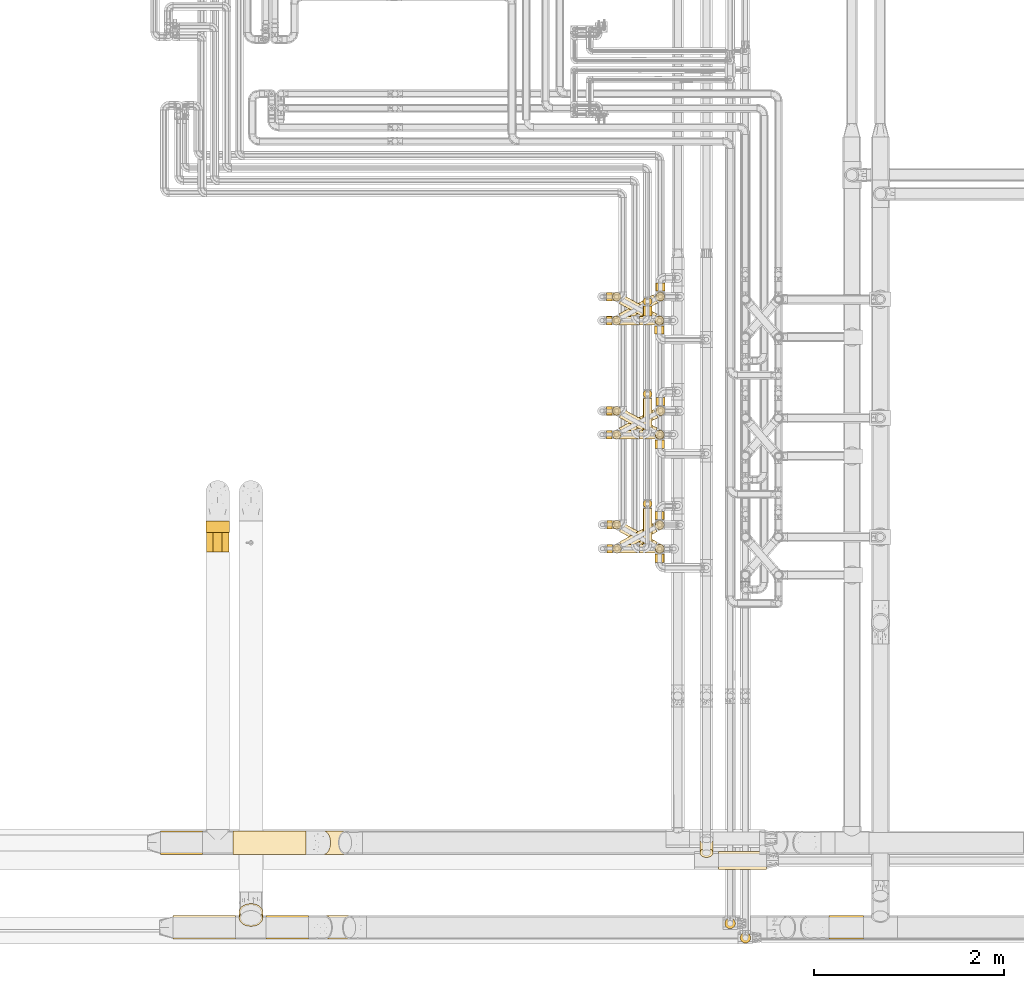
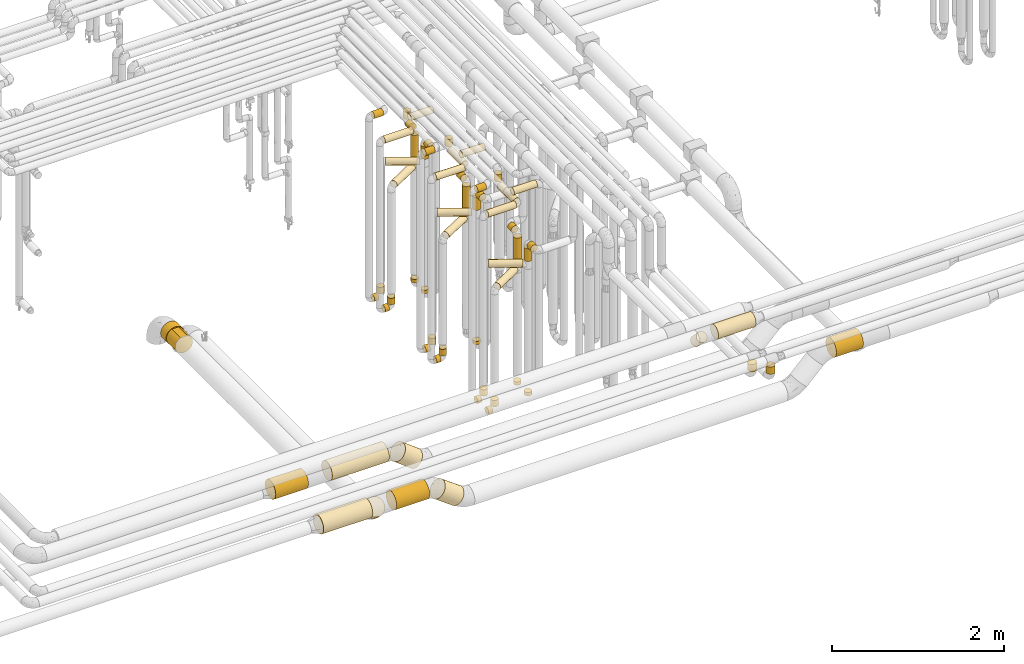
# One storey, part 11 of 827: 64 coverings.
"""IFC2X3 building model written with IfcOpenShell, lengths in millimetres."""

from ifc_helpers import new_model, entity, si_unit, converted_unit, derived_unit, direction, frame, frame_2d, origin, origin_2d_with_axis, place, context, subcontext, project, spatial, polyline, circle_curve, parameter, trimmed, segment, composite_curve, circle, outline, extrude, element, save


model = new_model("IFC2X3")

# Units and contexts
model_context = context("Model", 3, precision=0.01, world=origin(), true_north=direction((6.12303176911189e-17, 1.0)))
body_context = subcontext(model_context, "Body", "Model", "MODEL_VIEW")
ifc_project = project(units=[si_unit("LENGTHUNIT", "METRE", prefix="MILLI"), si_unit("AREAUNIT", "SQUARE_METRE"), si_unit("VOLUMEUNIT", "CUBIC_METRE"), converted_unit("PLANEANGLEUNIT", "DEGREE", entity("IfcRatioMeasure", 0.0174532925199433), si_unit("PLANEANGLEUNIT", "RADIAN"), dimensions=[0, 0, 0, 0, 0, 0, 0]), si_unit("MASSUNIT", "GRAM", prefix="KILO"), derived_unit("MASSDENSITYUNIT", [(si_unit("MASSUNIT", "GRAM", prefix="KILO"), 1), (si_unit("LENGTHUNIT", "METRE"), -3)]), derived_unit("MOMENTOFINERTIAUNIT", [(si_unit("LENGTHUNIT", "METRE"), 4)]), si_unit("TIMEUNIT", "SECOND"), si_unit("FREQUENCYUNIT", "HERTZ"), si_unit("THERMODYNAMICTEMPERATUREUNIT", "DEGREE_CELSIUS"), derived_unit("THERMALTRANSMITTANCEUNIT", [(si_unit("MASSUNIT", "GRAM", prefix="KILO"), 1), (si_unit("THERMODYNAMICTEMPERATUREUNIT", "KELVIN"), -1), (si_unit("TIMEUNIT", "SECOND"), -3)]), derived_unit("VOLUMETRICFLOWRATEUNIT", [(si_unit("LENGTHUNIT", "METRE"), 3), (si_unit("TIMEUNIT", "SECOND"), -1)]), derived_unit("MASSFLOWRATEUNIT", [(si_unit("MASSUNIT", "GRAM", prefix="KILO"), 1), (si_unit("TIMEUNIT", "SECOND"), -1)]), derived_unit("ROTATIONALFREQUENCYUNIT", [(si_unit("TIMEUNIT", "SECOND"), -1)]), si_unit("ELECTRICCURRENTUNIT", "AMPERE"), si_unit("ELECTRICVOLTAGEUNIT", "VOLT"), si_unit("POWERUNIT", "WATT"), si_unit("FORCEUNIT", "NEWTON", prefix="KILO"), si_unit("ILLUMINANCEUNIT", "LUX"), si_unit("LUMINOUSFLUXUNIT", "LUMEN"), si_unit("LUMINOUSINTENSITYUNIT", "CANDELA"), derived_unit("USERDEFINED", [(si_unit("MASSUNIT", "GRAM", prefix="KILO"), -1), (si_unit("LENGTHUNIT", "METRE"), -2), (si_unit("TIMEUNIT", "SECOND"), 3), (si_unit("LUMINOUSFLUXUNIT", "LUMEN"), 1)]), derived_unit("LINEARVELOCITYUNIT", [(si_unit("LENGTHUNIT", "METRE"), 1), (si_unit("TIMEUNIT", "SECOND"), -1)]), si_unit("PRESSUREUNIT", "PASCAL"), derived_unit("USERDEFINED", [(si_unit("LENGTHUNIT", "METRE"), -2), (si_unit("MASSUNIT", "GRAM", prefix="KILO"), 1), (si_unit("TIMEUNIT", "SECOND"), -2)]), derived_unit("LINEARFORCEUNIT", [(si_unit("MASSUNIT", "GRAM", prefix="KILO"), 1), (si_unit("LENGTHUNIT", "METRE"), 1), (si_unit("TIMEUNIT", "SECOND"), -2), (si_unit("LENGTHUNIT", "METRE"), -1)]), derived_unit("PLANARFORCEUNIT", [(si_unit("MASSUNIT", "GRAM", prefix="KILO"), 1), (si_unit("LENGTHUNIT", "METRE"), 1), (si_unit("TIMEUNIT", "SECOND"), -2), (si_unit("LENGTHUNIT", "METRE"), -2)])], contexts=[model_context])

# Site, building, storey
site_placement = place(None, origin())
site = spatial("IfcSite", under=ifc_project, at=site_placement, CompositionType="ELEMENT")
building_placement = place(site_placement, origin())
building = spatial("IfcBuilding", under=site, at=building_placement, CompositionType="ELEMENT")
storey_placement = place(building_placement, frame((0.0, 0.0, 28200.0)))
storey = spatial("IfcBuildingStorey", under=building, at=storey_placement, Name="08", CompositionType="ELEMENT", Elevation=28200.0)

# Coverings
covering_1_placement = place(storey_placement, frame((35168.03, 11508.46, 352.25)))
element("IfcCovering", 1, at=covering_1_placement, inside=storey, Name=":ADSK_", ObjectType=":ADSK_", PredefinedType="INSULATION", context=body_context, shape_type="SweptSolid", body=[
    extrude(circle(Radius=46.15, at=origin_2d_with_axis()), frame((0.0, 47.75, 47.75), z_axis=(1.0, 0.0, 0.0), x_axis=(0.0, 1.0, 0.0)), (0.0, 0.0, 1.0), 59.0000000000126),
])
covering_2_placement = place(storey_placement, frame((35227.29, 11508.46, 448.0)))
element("IfcCovering", 2, at=covering_2_placement, inside=storey, Name=":ADSK_", ObjectType=":ADSK_", PredefinedType="INSULATION", context=body_context, shape_type="SweptSolid", body=[
    extrude(circle(Radius=46.15, at=origin_2d_with_axis()), frame((47.75, 47.75, 0.0), z_axis=(0.0, 0.0, 1.0), x_axis=(0.0, 1.0, 0.0)), (0.0, 0.0, 1.0), 92.0000000000137),
])
covering_3_placement = place(storey_placement, frame((35173.03, 10309.34, 352.25)))
element("IfcCovering", 3, at=covering_3_placement, inside=storey, Name=":ADSK_", ObjectType=":ADSK_", PredefinedType="INSULATION", context=body_context, shape_type="SweptSolid", body=[
    extrude(circle(Radius=46.15, at=origin_2d_with_axis()), frame((0.0, 47.75, 47.75), z_axis=(1.0, 0.0, 0.0), x_axis=(0.0, 1.0, 0.0)), (0.0, 0.0, 1.0), 57.8337402419765),
])
covering_4_placement = place(storey_placement, frame((35231.12, 10309.34, 448.0)))
element("IfcCovering", 4, at=covering_4_placement, inside=storey, Name=":ADSK_", ObjectType=":ADSK_", PredefinedType="INSULATION", context=body_context, shape_type="SweptSolid", body=[
    extrude(circle(Radius=46.15, at=origin_2d_with_axis()), frame((47.75, 47.75, 0.0), z_axis=(0.0, 0.0, 1.0), x_axis=(0.0, 1.0, 0.0)), (0.0, 0.0, 1.0), 92.0000000000137),
])
covering_5_placement = place(storey_placement, frame((35680.3, 10558.46, 448.0)))
element("IfcCovering", 5, at=covering_5_placement, inside=storey, Name=":ADSK_", ObjectType=":ADSK_", PredefinedType="INSULATION", context=body_context, shape_type="SweptSolid", body=[
    extrude(circle(Radius=46.15, at=origin_2d_with_axis()), frame((47.75, 47.75, 0.0), z_axis=(0.0, 0.0, 1.0), x_axis=(0.0, -1.0, 0.0)), (0.0, 0.0, 1.0), 47.000000000011),
])
covering_6_placement = place(storey_placement, frame((35168.03, 11508.44, 2952.25)))
element("IfcCovering", 6, at=covering_6_placement, inside=storey, Name=":ADSK_", ObjectType=":ADSK_", PredefinedType="INSULATION", context=body_context, shape_type="SweptSolid", body=[
    extrude(circle(Radius=46.15, at=origin_2d_with_axis()), frame((0.0, 47.76, 47.75), z_axis=(1.0, -4.58022354030143e-05, 0.0), x_axis=(-4.58022354030143e-05, -1.0, 0.0)), (0.0, 0.0, 1.0), 384.054937940216),
])
covering_7_placement = place(storey_placement, frame((35552.35, 11604.18, 2952.25)))
element("IfcCovering", 7, at=covering_7_placement, inside=storey, Name=":ADSK_", ObjectType=":ADSK_", PredefinedType="INSULATION", context=body_context, shape_type="SweptSolid", body=[
    extrude(circle(Radius=46.15, at=origin_2d_with_axis()), frame((47.75, 0.0, 47.75), z_axis=(0.0, 1.0, 0.0), x_axis=(1.0, 0.0, 0.0)), (0.0, 0.0, 1.0), 331.019903361197),
])
covering_8_placement = place(storey_placement, frame((35552.35, 11935.46, 3048.0)))
element("IfcCovering", 8, at=covering_8_placement, inside=storey, Name=":ADSK_", ObjectType=":ADSK_", PredefinedType="INSULATION", context=body_context, shape_type="SweptSolid", body=[
    extrude(circle(Radius=46.15, at=origin_2d_with_axis()), frame((47.75, 47.75, 0.0), z_axis=(0.0, 0.0, 1.0), x_axis=(-1.0, 0.0, 0.0)), (0.0, 0.0, 1.0), 104.000000000011),
])
covering_9_placement = place(storey_placement, frame((35677.45, 10555.61, 2157.0)))
element("IfcCovering", 9, at=covering_9_placement, inside=storey, Name=":ADSK_", ObjectType=":ADSK_", PredefinedType="INSULATION", context=body_context, shape_type="SweptSolid", body=[
    extrude(circle(Radius=49.0, at=origin_2d_with_axis()), frame((50.6, 50.6, 0.0)), (0.0, 0.0, 1.0), 385.99999999999),
])
covering_10_placement = place(storey_placement, frame((35303.27, 10340.38, 2049.4)))
element("IfcCovering", 10, at=covering_10_placement, inside=storey, Name=":ADSK_", ObjectType=":ADSK_", PredefinedType="INSULATION", context=body_context, shape_type="SweptSolid", body=[
    extrude(circle(Radius=49.0, at=origin_2d_with_axis()), frame((25.41, 44.42, 50.6), z_axis=(0.873900740639492, 0.486104408033651, 0.0), x_axis=(0.486104408033651, -0.873900740639492, 0.0)), (0.0, 0.0, 1.0), 399.639020319073),
])
covering_11_placement = place(storey_placement, frame((35677.45, 10663.2, 2549.4)))
element("IfcCovering", 11, at=covering_11_placement, inside=storey, Name=":ADSK_", ObjectType=":ADSK_", PredefinedType="INSULATION", context=body_context, shape_type="SweptSolid", body=[
    extrude(circle(Radius=49.0, at=origin_2d_with_axis()), frame((50.6, 0.0, 50.6), z_axis=(0.0, 1.0, 0.0), x_axis=(-1.0, 0.0, 0.0)), (0.0, 0.0, 1.0), 85.9999999262502),
])
covering_12_placement = place(storey_placement, frame((35686.28, 11755.09, 2157.0)))
element("IfcCovering", 12, at=covering_12_placement, inside=storey, Name=":ADSK_", ObjectType=":ADSK_", PredefinedType="INSULATION", context=body_context, shape_type="SweptSolid", body=[
    extrude(circle(Radius=49.0, at=origin_2d_with_axis()), frame((50.58, 50.58, 0.0), z_axis=(0.0, 0.0, 1.0), x_axis=(0.47617625102764, -0.879349860952546, 0.0)), (0.0, 0.0, 1.0), 385.99999999999),
])
covering_13_placement = place(storey_placement, frame((35300.25, 11538.06, 2049.4)))
element("IfcCovering", 13, at=covering_13_placement, inside=storey, Name=":ADSK_", ObjectType=":ADSK_", PredefinedType="INSULATION", context=body_context, shape_type="SweptSolid", body=[
    extrude(circle(Radius=49.0, at=origin_2d_with_axis()), frame((24.93, 44.68, 50.6), z_axis=(0.879349860952551, 0.47617625102763, 0.0), x_axis=(-0.47617625102763, 0.879349860952551, 0.0)), (0.0, 0.0, 1.0), 411.156212335708),
])
covering_14_placement = place(storey_placement, frame((35686.26, 11862.67, 2549.4)))
element("IfcCovering", 14, at=covering_14_placement, inside=storey, Name=":ADSK_", ObjectType=":ADSK_", PredefinedType="INSULATION", context=body_context, shape_type="SweptSolid", body=[
    extrude(circle(Radius=49.0, at=origin_2d_with_axis()), frame((50.6, 0.0, 50.6), z_axis=(0.0, 1.0, 0.0), x_axis=(-1.0, 0.0, 0.0)), (0.0, 0.0, 1.0), 86.4113062809591),
])
covering_15_placement = place(storey_placement, frame((35683.56, 12960.1, 2157.0)))
element("IfcCovering", 15, at=covering_15_placement, inside=storey, Name=":ADSK_", ObjectType=":ADSK_", PredefinedType="INSULATION", context=body_context, shape_type="SweptSolid", body=[
    extrude(circle(Radius=49.0, at=origin_2d_with_axis()), frame((50.58, 50.58, 0.0), z_axis=(0.0, 0.0, 1.0), x_axis=(0.47617625102764, -0.879349860952546, 0.0)), (0.0, 0.0, 1.0), 385.999999999986),
])
covering_16_placement = place(storey_placement, frame((35297.3, 12738.15, 2049.4)))
element("IfcCovering", 16, at=covering_16_placement, inside=storey, Name=":ADSK_", ObjectType=":ADSK_", PredefinedType="INSULATION", context=body_context, shape_type="SweptSolid", body=[
    extrude(circle(Radius=49.0, at=origin_2d_with_axis()), frame((25.41, 44.42, 50.6), z_axis=(0.873900740639491, 0.486104408033654, 0.0), x_axis=(-0.486104408033654, 0.873900740639491, 0.0)), (0.0, 0.0, 1.0), 413.435297220392),
])
covering_17_placement = place(storey_placement, frame((35683.65, 13067.49, 2549.4)))
element("IfcCovering", 17, at=covering_17_placement, inside=storey, Name=":ADSK_", ObjectType=":ADSK_", PredefinedType="INSULATION", context=body_context, shape_type="SweptSolid", body=[
    extrude(circle(Radius=49.0, at=origin_2d_with_axis()), frame((50.6, 0.0, 50.6), z_axis=(0.0, 1.0, 0.0), x_axis=(-1.0, 0.0, 0.0)), (0.0, 0.0, 1.0), 81.5902938725307),
])
covering_18_placement = place(storey_placement, frame((35552.35, 10780.63, 3248.0)))
element("IfcCovering", 18, at=covering_18_placement, inside=storey, Name=":ADSK_", ObjectType=":ADSK_", PredefinedType="INSULATION", context=body_context, shape_type="SweptSolid", body=[
    extrude(circle(Radius=46.15, at=origin_2d_with_axis()), frame((47.75, 47.75, 0.0), z_axis=(0.0, 0.0, 1.0), x_axis=(-1.0, 0.0, 0.0)), (0.0, 0.0, 1.0), 103.999999999998),
])
covering_19_placement = place(storey_placement, frame((35552.35, 10405.08, 3152.25)))
element("IfcCovering", 19, at=covering_19_placement, inside=storey, Name=":ADSK_", ObjectType=":ADSK_", PredefinedType="INSULATION", context=body_context, shape_type="SweptSolid", body=[
    extrude(circle(Radius=46.15, at=origin_2d_with_axis()), frame((47.75, 0.0, 47.75), z_axis=(0.0, 1.0, 0.0), x_axis=(-1.0, 0.0, 0.0)), (0.0, 0.0, 1.0), 375.292233723899),
])
covering_20_placement = place(storey_placement, frame((35173.03, 10309.34, 3152.25)))
element("IfcCovering", 20, at=covering_20_placement, inside=storey, Name=":ADSK_", ObjectType=":ADSK_", PredefinedType="INSULATION", context=body_context, shape_type="SweptSolid", body=[
    extrude(circle(Radius=46.15, at=origin_2d_with_axis()), frame((0.0, 47.75, 47.75), z_axis=(1.0, 0.0, 0.0), x_axis=(0.0, 1.0, 0.0)), (0.0, 0.0, 1.0), 379.057450000017),
])
covering_21_placement = place(storey_placement, frame((35168.03, 11758.46, 352.25)))
element("IfcCovering", 21, at=covering_21_placement, inside=storey, Name=":ADSK_", ObjectType=":ADSK_", PredefinedType="INSULATION", context=body_context, shape_type="SweptSolid", body=[
    extrude(circle(Radius=46.15, at=origin_2d_with_axis()), frame((0.0, 47.75, 47.75), z_axis=(1.0, 0.0, 0.0), x_axis=(0.0, 1.0, 0.0)), (0.0, 0.0, 1.0), 60.205336192978),
])
covering_22_placement = place(storey_placement, frame((35228.49, 11758.46, 448.0)))
element("IfcCovering", 22, at=covering_22_placement, inside=storey, Name=":ADSK_", ObjectType=":ADSK_", PredefinedType="INSULATION", context=body_context, shape_type="SweptSolid", body=[
    extrude(circle(Radius=46.15, at=origin_2d_with_axis()), frame((47.75, 47.75, 0.0), z_axis=(0.0, 0.0, 1.0), x_axis=(0.0, 1.0, 0.0)), (0.0, 0.0, 1.0), 92.0000000000094),
])
covering_23_placement = place(storey_placement, frame((35681.04, 11508.42, 447.94)))
element("IfcCovering", 23, at=covering_23_placement, inside=storey, Name=":ADSK_", ObjectType=":ADSK_", PredefinedType="INSULATION", context=body_context, shape_type="SweptSolid", body=[
    extrude(circle(Radius=46.15, at=origin_2d_with_axis()), frame((47.75, 47.75, 0.06), z_axis=(0.0, 0.00137558663897165, 0.999999053880252), x_axis=(0.0, 0.999999053880252, -0.00137558663897165)), (0.0, 0.0, 1.0), 47.0000771237188),
])
covering_24_placement = place(storey_placement, frame((35173.03, 10561.4, 352.25)))
element("IfcCovering", 24, at=covering_24_placement, inside=storey, Name=":ADSK_", ObjectType=":ADSK_", PredefinedType="INSULATION", context=body_context, shape_type="SweptSolid", body=[
    extrude(circle(Radius=46.15, at=origin_2d_with_axis()), frame((0.0, 47.75, 47.75), z_axis=(1.0, 0.0, 0.0), x_axis=(0.0, 1.0, 0.0)), (0.0, 0.0, 1.0), 55.7044279710415),
])
covering_25_placement = place(storey_placement, frame((35228.99, 10561.4, 448.0)))
element("IfcCovering", 25, at=covering_25_placement, inside=storey, Name=":ADSK_", ObjectType=":ADSK_", PredefinedType="INSULATION", context=body_context, shape_type="SweptSolid", body=[
    extrude(circle(Radius=46.15, at=origin_2d_with_axis()), frame((47.75, 47.75, 0.0), z_axis=(0.0, 0.0, 1.0), x_axis=(0.0, 1.0, 0.0)), (0.0, 0.0, 1.0), 92.0000000000094),
])
covering_26_placement = place(storey_placement, frame((35680.3, 10308.42, 448.0)))
element("IfcCovering", 26, at=covering_26_placement, inside=storey, Name=":ADSK_", ObjectType=":ADSK_", PredefinedType="INSULATION", context=body_context, shape_type="SweptSolid", body=[
    extrude(circle(Radius=46.15, at=origin_2d_with_axis()), frame((47.75, 47.75, 0.0), z_axis=(0.0, 0.0, 1.0), x_axis=(0.0, -1.0, 0.0)), (0.0, 0.0, 1.0), 47.0000000000153),
])
covering_27_placement = place(storey_placement, frame((36344.03, 6983.4, 3003.4)))
element("IfcCovering", 27, at=covering_27_placement, inside=storey, Name=":ADSK_", ObjectType=":ADSK_", PredefinedType="INSULATION", context=body_context, shape_type="SweptSolid", body=[
    extrude(circle(Radius=95.0, at=origin_2d_with_axis()), frame((0.0, 96.6, 96.6), z_axis=(1.0, 0.0, 0.0), x_axis=(0.0, -1.0, 0.0)), (0.0, 0.0, 1.0), 508.799297490111),
])
covering_28_placement = place(storey_placement, frame((35168.03, 11758.46, 3152.25)))
element("IfcCovering", 28, at=covering_28_placement, inside=storey, Name=":ADSK_", ObjectType=":ADSK_", PredefinedType="INSULATION", context=body_context, shape_type="SweptSolid", body=[
    extrude(circle(Radius=46.15, at=origin_2d_with_axis()), frame((0.0, 47.75, 47.75), z_axis=(1.0, 0.0, 0.0), x_axis=(0.0, 1.0, 0.0)), (0.0, 0.0, 1.0), 124.000000000024),
])
covering_29_placement = place(storey_placement, frame((35518.03, 11508.42, 3152.25)))
element("IfcCovering", 29, at=covering_29_placement, inside=storey, Name=":ADSK_", ObjectType=":ADSK_", PredefinedType="INSULATION", context=body_context, shape_type="SweptSolid", body=[
    extrude(circle(Radius=46.15, at=origin_2d_with_axis()), frame((0.0, 47.75, 47.75), z_axis=(1.0, 0.0, 0.0), x_axis=(0.0, -1.0, 0.0)), (0.0, 0.0, 1.0), 307.750000000047),
])
covering_30_placement = place(storey_placement, frame((35677.45, 10305.57, 2362.0)))
element("IfcCovering", 30, at=covering_30_placement, inside=storey, Name=":ADSK_", ObjectType=":ADSK_", PredefinedType="INSULATION", context=body_context, shape_type="SweptSolid", body=[
    extrude(circle(Radius=49.0, at=origin_2d_with_axis()), frame((50.6, 50.6, 0.0)), (0.0, 0.0, 1.0), 181.000000000002),
])
covering_31_placement = place(storey_placement, frame((35300.91, 10339.7, 2254.4)))
element("IfcCovering", 31, at=covering_31_placement, inside=storey, Name=":ADSK_", ObjectType=":ADSK_", PredefinedType="INSULATION", context=body_context, shape_type="SweptSolid", body=[
    extrude(circle(Radius=49.0, at=origin_2d_with_axis()), frame((25.55, 241.55, 50.6), z_axis=(0.872328835264981, -0.488919628533404, 0.0), x_axis=(-0.488919628533404, -0.872328835264981, 0.0)), (0.0, 0.0, 1.0), 403.365689374244),
])
covering_32_placement = place(storey_placement, frame((35677.45, 10213.2, 2549.4)))
element("IfcCovering", 32, at=covering_32_placement, inside=storey, Name=":ADSK_", ObjectType=":ADSK_", PredefinedType="INSULATION", context=body_context, shape_type="SweptSolid", body=[
    extrude(circle(Radius=49.0, at=origin_2d_with_axis()), frame((50.6, 0.0, 50.6), z_axis=(0.0, 1.0, 0.0), x_axis=(1.0, 0.0, 0.0)), (0.0, 0.0, 1.0), 85.9654132835041),
])
covering_33_placement = place(storey_placement, frame((35678.19, 11503.87, 2362.0)))
element("IfcCovering", 33, at=covering_33_placement, inside=storey, Name=":ADSK_", ObjectType=":ADSK_", PredefinedType="INSULATION", context=body_context, shape_type="SweptSolid", body=[
    extrude(circle(Radius=49.0, at=origin_2d_with_axis()), frame((50.59, 50.59, 0.0), z_axis=(0.0, 0.0, 1.0), x_axis=(-0.494757339901244, -0.869031170104873, 0.0)), (0.0, 0.0, 1.0), 180.999999999998),
])
covering_34_placement = place(storey_placement, frame((35300.46, 11538.31, 2254.4)))
element("IfcCovering", 34, at=covering_34_placement, inside=storey, Name=":ADSK_", ObjectType=":ADSK_", PredefinedType="INSULATION", context=body_context, shape_type="SweptSolid", body=[
    extrude(circle(Radius=49.0, at=origin_2d_with_axis()), frame((25.52, 241.99, 50.6), z_axis=(0.872709848733326, -0.488239203591698, 0.0), x_axis=(0.488239203591698, 0.872709848733326, 0.0)), (0.0, 0.0, 1.0), 404.791381976554),
])
covering_35_placement = place(storey_placement, frame((35678.19, 11413.08, 2549.4)))
element("IfcCovering", 35, at=covering_35_placement, inside=storey, Name=":ADSK_", ObjectType=":ADSK_", PredefinedType="INSULATION", context=body_context, shape_type="SweptSolid", body=[
    extrude(circle(Radius=49.0, at=origin_2d_with_axis()), frame((50.6, 0.0, 50.6), z_axis=(0.0, 1.0, 0.0), x_axis=(1.0, 0.0, 0.0)), (0.0, 0.0, 1.0), 84.3822522691391),
])
covering_36_placement = place(storey_placement, frame((35674.65, 12704.08, 2362.0)))
element("IfcCovering", 36, at=covering_36_placement, inside=storey, Name=":ADSK_", ObjectType=":ADSK_", PredefinedType="INSULATION", context=body_context, shape_type="SweptSolid", body=[
    extrude(circle(Radius=49.0, at=origin_2d_with_axis()), frame((50.38, 50.38, 0.0), z_axis=(0.0, 0.0, 1.0), x_axis=(-0.579093053123268, -0.81526145243374, 0.0)), (0.0, 0.0, 1.0), 180.999999999993),
])
covering_37_placement = place(storey_placement, frame((35299.57, 12738.31, 2254.4)))
element("IfcCovering", 37, at=covering_37_placement, inside=storey, Name=":ADSK_", ObjectType=":ADSK_", PredefinedType="INSULATION", context=body_context, shape_type="SweptSolid", body=[
    extrude(circle(Radius=49.0, at=origin_2d_with_axis()), frame((25.52, 240.4, 50.6), z_axis=(0.872709832917215, -0.488239231862421, 0.0), x_axis=(0.488239231862421, 0.872709832917215, 0.0)), (0.0, 0.0, 1.0), 401.518720143664),
])
covering_38_placement = place(storey_placement, frame((35674.44, 12613.08, 2549.4)))
element("IfcCovering", 38, at=covering_38_placement, inside=storey, Name=":ADSK_", ObjectType=":ADSK_", PredefinedType="INSULATION", context=body_context, shape_type="SweptSolid", body=[
    extrude(circle(Radius=49.0, at=origin_2d_with_axis()), frame((50.6, 0.0, 50.6), z_axis=(0.0, 1.0, 0.0), x_axis=(1.0, 0.0, 0.0)), (0.0, 0.0, 1.0), 84.38225226915),
])
covering_39_placement = place(storey_placement, frame((35173.03, 10561.4, 3352.25)))
element("IfcCovering", 39, at=covering_39_placement, inside=storey, Name=":ADSK_", ObjectType=":ADSK_", PredefinedType="INSULATION", context=body_context, shape_type="SweptSolid", body=[
    extrude(circle(Radius=46.15, at=origin_2d_with_axis()), frame((0.0, 47.75, 47.75), z_axis=(1.0, 0.0, 0.0), x_axis=(0.0, 1.0, 0.0)), (0.0, 0.0, 1.0), 119.000000000016),
])
covering_40_placement = place(storey_placement, frame((35518.03, 10308.42, 3352.25)))
element("IfcCovering", 40, at=covering_40_placement, inside=storey, Name=":ADSK_", ObjectType=":ADSK_", PredefinedType="INSULATION", context=body_context, shape_type="SweptSolid", body=[
    extrude(circle(Radius=46.15, at=origin_2d_with_axis()), frame((0.0, 47.75, 47.75), z_axis=(1.0, 0.0, 0.0), x_axis=(0.0, 1.0, 0.0)), (0.0, 0.0, 1.0), 312.75000000005),
])
covering_41_placement = place(storey_placement, frame((35168.03, 12708.46, 352.25)))
element("IfcCovering", 41, at=covering_41_placement, inside=storey, Name=":ADSK_", ObjectType=":ADSK_", PredefinedType="INSULATION", context=body_context, shape_type="SweptSolid", body=[
    extrude(circle(Radius=46.15, at=origin_2d_with_axis()), frame((0.0, 47.75, 47.75), z_axis=(1.0, 0.0, 0.0), x_axis=(0.0, 1.0, 0.0)), (0.0, 0.0, 1.0), 56.8702533571783),
])
covering_42_placement = place(storey_placement, frame((35225.16, 12708.46, 448.0)))
element("IfcCovering", 42, at=covering_42_placement, inside=storey, Name=":ADSK_", ObjectType=":ADSK_", PredefinedType="INSULATION", context=body_context, shape_type="SweptSolid", body=[
    extrude(circle(Radius=46.15, at=origin_2d_with_axis()), frame((47.75, 47.75, 0.0), z_axis=(0.0, 0.0, 1.0), x_axis=(0.0, 1.0, 0.0)), (0.0, 0.0, 1.0), 92.0000000000094),
])
covering_43_placement = place(storey_placement, frame((35552.35, 12908.43, 2847.61)))
element("IfcCovering", 43, at=covering_43_placement, inside=storey, Name=":ADSK_", ObjectType=":ADSK_", PredefinedType="INSULATION", context=body_context, shape_type="SweptSolid", body=[
    extrude(circle(Radius=46.15, at=origin_2d_with_axis()), frame((47.75, 47.75, 0.0), z_axis=(0.0, 0.0, 1.0), x_axis=(-1.0, 0.0, 0.0)), (0.0, 0.0, 1.0), 104.39114387437),
])
covering_44_placement = place(storey_placement, frame((35552.35, 12804.17, 2751.86)))
element("IfcCovering", 44, at=covering_44_placement, inside=storey, Name=":ADSK_", ObjectType=":ADSK_", PredefinedType="INSULATION", context=body_context, shape_type="SweptSolid", body=[
    extrude(circle(Radius=46.15, at=origin_2d_with_axis()), frame((47.75, 0.0, 47.75), z_axis=(0.0, 1.0, 0.0), x_axis=(1.0, 0.0, 0.0)), (0.0, 0.0, 1.0), 104.000000000018),
])
covering_45_placement = place(storey_placement, frame((35168.03, 12708.43, 2751.86)))
element("IfcCovering", 45, at=covering_45_placement, inside=storey, Name=":ADSK_", ObjectType=":ADSK_", PredefinedType="INSULATION", context=body_context, shape_type="SweptSolid", body=[
    extrude(circle(Radius=46.15, at=origin_2d_with_axis()), frame((0.0, 47.77, 47.75), z_axis=(0.999999997789185, -6.64953413086212e-05, 0.0), x_axis=(6.64953413086212e-05, 0.999999997789185, 0.0)), (0.0, 0.0, 1.0), 384.054259178842),
])
covering_46_placement = place(storey_placement, frame((35518.03, 12708.42, 2952.25)))
element("IfcCovering", 46, at=covering_46_placement, inside=storey, Name=":ADSK_", ObjectType=":ADSK_", PredefinedType="INSULATION", context=body_context, shape_type="SweptSolid", body=[
    extrude(circle(Radius=46.15, at=origin_2d_with_axis()), frame((0.0, 47.75, 47.75), z_axis=(1.0, 0.0, 0.0), x_axis=(0.0, 1.0, 0.0)), (0.0, 0.0, 1.0), 307.750000000012),
])
for number, where, name in (
    (47, (35677.29, 12708.42, 448.0), ":ADSK_"),
    (48, (35686.39, 12958.46, 448.0), ":ADSK_"),
):
    element("IfcCovering", number, at=place(storey_placement, frame(where)), inside=storey, Name=name, ObjectType=":ADSK_", PredefinedType="INSULATION", context=body_context, shape_type="SweptSolid", body=[
        extrude(circle(Radius=46.15, at=origin_2d_with_axis()), frame((47.75, 47.75, 0.0), z_axis=(0.0, 0.0, 1.0), x_axis=(0.0, -1.0, 0.0)), (0.0, 0.0, 1.0), 47.000000000011),
    ])
covering_47_placement = place(storey_placement, frame((35168.03, 12958.46, 2952.25)))
element("IfcCovering", 49, at=covering_47_placement, inside=storey, Name=":ADSK_", ObjectType=":ADSK_", PredefinedType="INSULATION", context=body_context, shape_type="SweptSolid", body=[
    extrude(circle(Radius=46.15, at=origin_2d_with_axis()), frame((0.0, 47.75, 47.75), z_axis=(1.0, 0.0, 0.0), x_axis=(0.0, -1.0, 0.0)), (0.0, 0.0, 1.0), 124.000000000015),
])
covering_48_placement = place(storey_placement, frame((35168.03, 12958.46, 352.25)))
element("IfcCovering", 50, at=covering_48_placement, inside=storey, Name=":ADSK_", ObjectType=":ADSK_", PredefinedType="INSULATION", context=body_context, shape_type="SweptSolid", body=[
    extrude(circle(Radius=46.15, at=origin_2d_with_axis()), frame((0.0, 47.75, 47.75), z_axis=(1.0, 0.0, 0.0), x_axis=(0.0, 1.0, 0.0)), (0.0, 0.0, 1.0), 59.3114268710131),
])
covering_49_placement = place(storey_placement, frame((35227.6, 12958.46, 448.0)))
element("IfcCovering", 51, at=covering_49_placement, inside=storey, Name=":ADSK_", ObjectType=":ADSK_", PredefinedType="INSULATION", context=body_context, shape_type="SweptSolid", body=[
    extrude(circle(Radius=46.15, at=origin_2d_with_axis()), frame((47.75, 47.75, 0.0), z_axis=(0.0, 0.0, 1.0), x_axis=(0.0, 1.0, 0.0)), (0.0, 0.0, 1.0), 92.0000000000094),
])
covering_50_placement = place(storey_placement, frame((30953.9, 10524.83, 2673.9)))
element("IfcCovering", 52, at=covering_50_placement, inside=storey, Name=":ADSK_", ObjectType=":ADSK_", PredefinedType="INSULATION", context=body_context, shape_type="SweptSolid", body=[
    extrude(outline(polyline([(-16.25, -123.43), (16.25, -123.43), (47.64, -115.02), (75.79, -98.77), (98.77, -75.79), (115.02, -47.64), (123.43, -16.25), (123.43, 16.25), (115.02, 47.64), (98.77, 75.79), (75.79, 98.77), (47.64, 115.02), (16.25, 123.43), (-16.25, 123.43), (-47.64, 115.02), (-75.79, 98.77), (-98.77, 75.79), (-115.02, 47.64), (-123.43, 16.25), (-123.43, -16.25), (-115.02, -47.64), (-98.77, -75.79), (-75.79, -98.77), (-47.64, -115.02), (-16.25, -123.43)])), frame((126.1, 0.0, 126.1), z_axis=(3.15716611416897e-09, 1.0, 0.0), x_axis=(-0.130526192220075, 0.0, -0.991444861373807)), (0.0, 0.0, 1.0), 125.173920988328),
])
covering_51_placement = place(storey_placement, frame((30479.76, 7140.11, 2673.9)))
element("IfcCovering", 53, at=covering_51_placement, inside=storey, Name=":ADSK_", ObjectType=":ADSK_", PredefinedType="INSULATION", context=body_context, shape_type="SweptSolid", body=[
    extrude(circle(Radius=124.5, at=origin_2d_with_axis()), frame((0.0, 126.1, 126.1), z_axis=(1.0, 0.0, -2.62756642280565e-06), x_axis=(0.0, -1.0, 0.0)), (0.0, 0.0, 1.0), 440.240643086704),
])
covering_52_placement = place(storey_placement, frame((31240.0, 7140.11, 2673.9)))
element("IfcCovering", 54, at=covering_52_placement, inside=storey, Name=":ADSK_", ObjectType=":ADSK_", PredefinedType="INSULATION", context=body_context, shape_type="SweptSolid", body=[
    extrude(circle(Radius=124.5, at=origin_2d_with_axis()), frame((0.0, 126.1, 126.1), z_axis=(1.0, 0.0, 0.0), x_axis=(0.0, 1.0, 0.0)), (0.0, 0.0, 1.0), 768.43288548493),
])
covering_53_placement = place(storey_placement, frame((36149.19, 7107.79, 2832.83)))
element("IfcCovering", 55, at=covering_53_placement, inside=storey, Name=":ADSK_", ObjectType=":ADSK_", PredefinedType="INSULATION", context=body_context, shape_type="SweptSolid", body=[
    extrude(circle(Radius=69.25, at=origin_2d_with_axis()), frame((70.85, 188.55, 50.56), z_axis=(0.0, -0.707106781186553, 0.707106781186542), x_axis=(-1.0, 0.0, 0.0)), (0.0, 0.0, 1.0), 195.141869989341),
])
covering_54_placement = place(storey_placement, frame((36412.12, 6359.97, 2926.0)))
element("IfcCovering", 56, at=covering_54_placement, inside=storey, Name=":ADSK_", ObjectType=":ADSK_", PredefinedType="INSULATION", context=body_context, shape_type="SweptSolid", body=[
    extrude(circle(Radius=55.0, at=origin_2d_with_axis()), frame((56.6, 56.6, 0.0), z_axis=(0.0, 0.0, 1.0), x_axis=(0.0, -1.0, 0.0)), (0.0, 0.0, 1.0), 104.000000000007),
])
covering_55_placement = place(storey_placement, frame((36573.05, 6209.22, 2926.0)))
element("IfcCovering", 57, at=covering_55_placement, inside=storey, Name=":ADSK_", ObjectType=":ADSK_", PredefinedType="INSULATION", context=body_context, shape_type="SweptSolid", body=[
    extrude(circle(Radius=55.0, at=origin_2d_with_axis()), frame((56.6, 56.6, 0.0), z_axis=(0.0, 0.0, 1.0), x_axis=(0.0, -1.0, 0.0)), (0.0, 0.0, 1.0), 104.000075851891),
])
covering_56_placement = place(storey_placement, frame((30610.11, 6248.9, 2673.9)))
element("IfcCovering", 58, at=covering_56_placement, inside=storey, Name=":ADSK_", ObjectType=":ADSK_", PredefinedType="INSULATION", context=body_context, shape_type="SweptSolid", body=[
    extrude(circle(Radius=124.5, at=origin_2d_with_axis()), frame((0.0, 126.1, 126.1), z_axis=(1.0, 0.0, 0.0), x_axis=(0.0, -1.0, 0.0)), (0.0, 0.0, 1.0), 659.891728032664),
])
covering_57_placement = place(storey_placement, frame((31590.0, 6248.9, 2673.9)))
element("IfcCovering", 59, at=covering_57_placement, inside=storey, Name=":ADSK_", ObjectType=":ADSK_", PredefinedType="INSULATION", context=body_context, shape_type="SweptSolid", body=[
    extrude(circle(Radius=124.5, at=origin_2d_with_axis()), frame((0.0, 126.1, 126.1), z_axis=(1.0, 0.0, 0.0), x_axis=(0.0, -0.707106781186543, -0.707106781186552)), (0.0, 0.0, 1.0), 446.080617390533),
])
covering_58_placement = place(storey_placement, frame((31303.9, 6384.36, 2548.24)))
element("IfcCovering", 60, at=covering_58_placement, inside=storey, Name=":ADSK_", ObjectType=":ADSK_", PredefinedType="INSULATION", context=body_context, shape_type="SweptSolid", body=[
    extrude(circle(Radius=124.5, at=origin_2d_with_axis()), frame((126.1, 89.63, 152.77), z_axis=(0.0, 0.707106781186537, -0.707106781186558), x_axis=(1.0, 0.0, 0.0)), (0.0, 0.0, 1.0), 89.289321881383),
])
covering_59_placement = place(storey_placement, frame((32137.86, 6248.9, 2455.36)))
element("IfcCovering", 61, at=covering_59_placement, inside=storey, Name=":ADSK_", ObjectType=":ADSK_", PredefinedType="INSULATION", context=body_context, shape_type="SweptSolid", body=[
    extrude(circle(Radius=124.5, at=origin_2d_with_axis()), frame((328.57, 126.1, 102.21), z_axis=(-0.808117884699288, 0.0, 0.589020784377893), x_axis=(0.0, 1.0, 0.0)), (0.0, 0.0, 1.0), 313.861133125843),
])
covering_60_placement = place(storey_placement, frame((37506.49, 6248.9, 2773.9)))
element("IfcCovering", 62, at=covering_60_placement, inside=storey, Name=":ADSK_", ObjectType=":ADSK_", PredefinedType="INSULATION", context=body_context, shape_type="SweptSolid", body=[
    extrude(circle(Radius=124.5, at=origin_2d_with_axis()), frame((0.0, 126.1, 126.1), z_axis=(1.0, 0.0, 0.0), x_axis=(0.0, -1.0, 0.0)), (0.0, 0.0, 1.0), 363.810001287764),
])
covering_61_placement = place(storey_placement, frame((32113.45, 7140.11, 2461.17)))
element("IfcCovering", 63, at=covering_61_placement, inside=storey, Name=":ADSK_", ObjectType=":ADSK_", PredefinedType="INSULATION", context=body_context, shape_type="SweptSolid", body=[
    extrude(circle(Radius=124.5, at=origin_2d_with_axis()), frame((308.18, 126.1, 100.49), z_axis=(-0.794332086218718, 0.0, 0.607483774930178), x_axis=(0.0, -1.0, 0.0)), (0.0, 0.0, 1.0), 290.756106971443),
])
covering_62_placement = place(storey_placement, frame((30960.9, 10319.83, 2680.9)))
element("IfcCovering", 64, at=covering_62_placement, inside=storey, Name=":ADSK_", ObjectType=":ADSK_", PredefinedType="INSULATION", context=body_context, shape_type="SweptSolid", body=[
    extrude(outline(composite_curve([segment(trimmed(circle_curve(frame_2d((19.5, 0.0), x_axis=(1.0, 0.0)), 117.5), [parameter(0.0)], [parameter(90.0)], True, "PARAMETER"), True, "CONTINUOUS"), segment(trimmed(circle_curve(frame_2d((19.5, 0.0), x_axis=(1.0, 0.0)), 117.5), [parameter(90.0)], [parameter(156.190623774301)], True, "PARAMETER"), True, "CONTINUOUS"), segment(polyline([(-88.0, 47.43), (-88.0, -47.43)]), True, "CONTINUOUS"), segment(trimmed(circle_curve(frame_2d((19.5, 0.0), x_axis=(1.0, 0.0)), 117.5), [parameter(203.8093762257)], [parameter(270.0)], True, "PARAMETER"), True, "CONTINUOUS"), segment(trimmed(circle_curve(frame_2d((19.5, 0.0), x_axis=(1.0, 0.0)), 117.5), [parameter(270.0)], [parameter(0.0)], True, "PARAMETER"), True, "CONTINUOUS")], self_intersect=False)), frame((119.1, 0.0, 138.6), z_axis=(0.0, 1.0, 0.0), x_axis=(1.0136969447085e-07, 0.0, -1.0)), (0.0, 0.0, 1.0), 204.999999999997),
])

save(model, "model.ifc")
